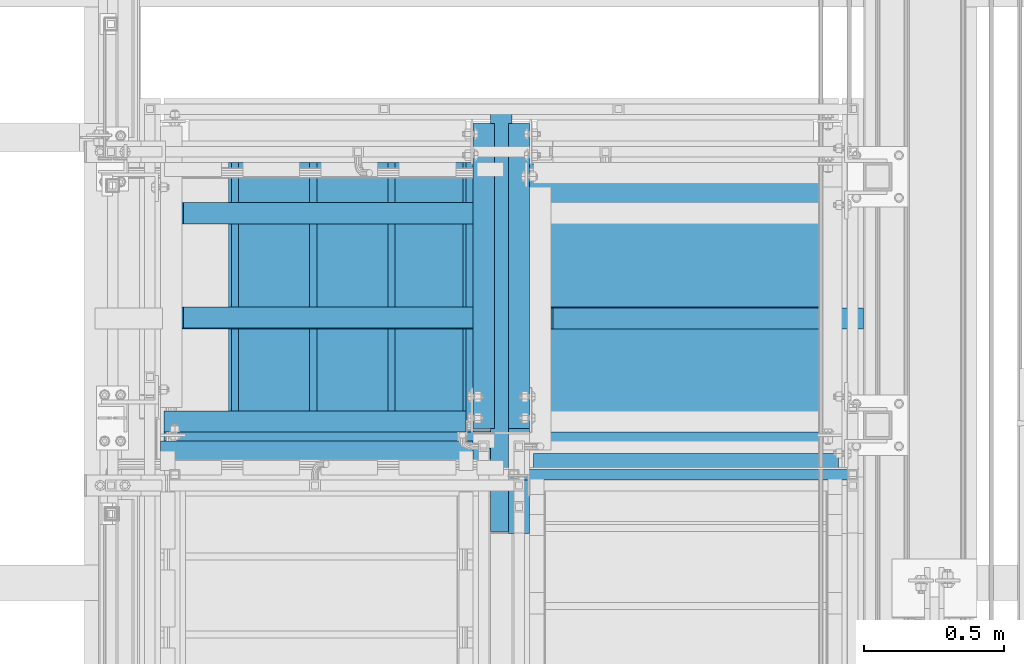
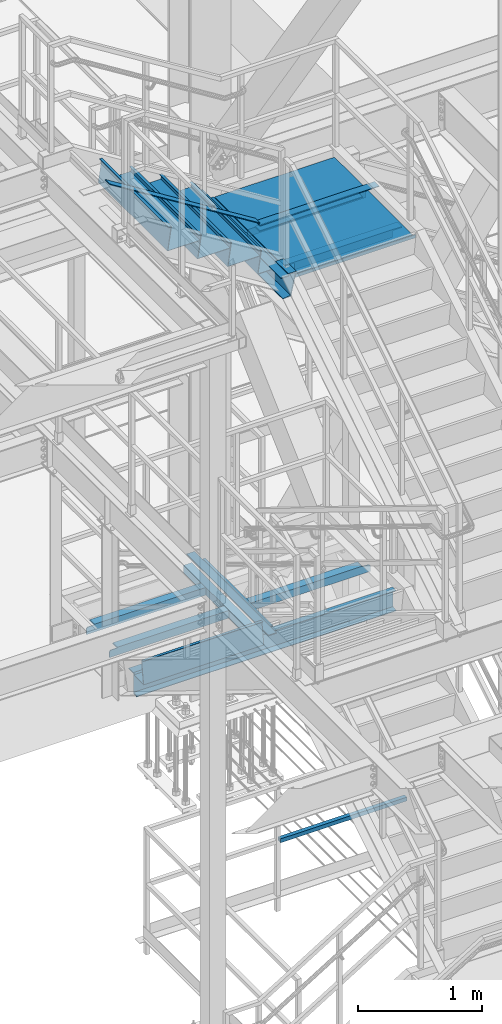
# One storey, part 1774 of 3843: 20 beams, 2 members, 14 elements without a shape of their own.
"""IFC2X3 building model written with IfcOpenShell, lengths in millimetres."""

import ifcopenshell
import ifcopenshell.guid

model = None  # the IFC model being written
_history = None  # IfcOwnerHistory: only IFC2X3 demands one
_inside = {}  # id of a spatial element -> (the spatial element, [elements in it])
_under = {}  # id of a project, library or spatial element -> (it, [spatial elements below it])
_declared = {}  # id of a project -> (the project, [libraries it declares])
_typed = {}  # id of a type object -> (the type object, [elements of that type])
_made_of = {}  # id of a material, layer set ... -> (it, [elements and type objects made of it])


def new_model(schema):
    """Start an empty IFC model of exactly this schema.

    Asked for "IFC4X3", IfcOpenShell would pick the latest addendum, in which some entities
    have other attributes; the version numbers below select the first issue.
    IFC2X3 requires an IfcOwnerHistory on every rooted entity: one is made here for all.
    """
    global model, _history
    if schema == "IFC4X3":
        model = ifcopenshell.file(schema_version=(4, 3, 0, 0))
    else:
        model = ifcopenshell.file(schema=schema)
    _inside.clear()
    _under.clear()
    _declared.clear()
    _typed.clear()
    _made_of.clear()
    _history = None
    if model.schema == "IFC2X3":
        org = make("IfcOrganization", Name="unknown")
        user = make(
            "IfcPersonAndOrganization",
            ThePerson=make("IfcPerson", FamilyName="unknown"),
            TheOrganization=org,
        )
        app = make(
            "IfcApplication",
            ApplicationDeveloper=org,
            Version="unknown",
            ApplicationFullName="unknown",
            ApplicationIdentifier="unknown",
        )
        _history = make(
            "IfcOwnerHistory",
            OwningUser=user,
            OwningApplication=app,
            ChangeAction="ADDED",
            CreationDate=0,
        )
    return model


def make(cls, **values):
    """One entity of the class cls with the attributes given. An attribute that is None is left unset."""
    return model.create_entity(
        cls, **{name: value for name, value in values.items() if value is not None}
    )


def rooted(cls, **values):
    """An entity with a GlobalId (a new one), such as an element, a storey or a relation."""
    return make(cls, GlobalId=ifcopenshell.guid.new(), OwnerHistory=_history, **values)


def si_unit(unit_type, name, prefix=None):
    """IfcSIUnit, for example si_unit("LENGTHUNIT", "METRE", prefix="MILLI")."""
    return make("IfcSIUnit", UnitType=unit_type, Prefix=prefix, Name=name)


def assignment(units):
    """IfcUnitAssignment: the units of a project."""
    return None if units is None else make("IfcUnitAssignment", Units=units)


def point(xyz):
    """IfcCartesianPoint."""
    return None if xyz is None else make("IfcCartesianPoint", Coordinates=xyz)


def direction(xyz):
    """IfcDirection."""
    return None if xyz is None else make("IfcDirection", DirectionRatios=xyz)


def frame(location, z_axis=None, x_axis=None):
    """IfcAxis2Placement3D, a coordinate frame: its origin and axes. An axis left out is left unset."""
    return make(
        "IfcAxis2Placement3D",
        Location=point(location),
        Axis=direction(z_axis),
        RefDirection=direction(x_axis),
    )


def origin_with_axes():
    """The frame at (0, 0, 0) with the z axis (0, 0, 1) and the x axis (1, 0, 0) written out."""
    return frame((0.0, 0.0, 0.0), z_axis=(0.0, 0.0, 1.0), x_axis=(1.0, 0.0, 0.0))


def place(relative_to, where):
    """IfcLocalPlacement: puts the frame where relative to a parent placement (None: the world)."""
    return make(
        "IfcLocalPlacement", PlacementRelTo=relative_to, RelativePlacement=where
    )


def context(
    kind, dimensions, precision=None, world=None, true_north=None, identifier=None
):
    """IfcGeometricRepresentationContext, for example the 3D "Model" context."""
    return make(
        "IfcGeometricRepresentationContext",
        ContextIdentifier=identifier,
        ContextType=kind,
        CoordinateSpaceDimension=dimensions,
        Precision=precision,
        WorldCoordinateSystem=world,
        TrueNorth=true_north,
    )


def subcontext(parent, identifier, kind, view, scale=None):
    """IfcGeometricRepresentationSubContext, for example "Body" below "Model"."""
    return make(
        "IfcGeometricRepresentationSubContext",
        ContextIdentifier=identifier,
        ContextType=kind,
        ParentContext=parent,
        TargetScale=scale,
        TargetView=view,
    )


def project(units=None, contexts=None):
    """IfcProject with its units and contexts."""
    return rooted(
        "IfcProject",
        Name="project",
        RepresentationContexts=contexts,
        UnitsInContext=assignment(units),
    )


def spatial(cls, under=None, at=None, **own):
    """A site, building, storey or space (cls), placed at a placement, below another one or the project."""
    s = rooted(cls, ObjectPlacement=at, **own)
    if under is not None:
        _under.setdefault(under.id(), (under, []))[1].append(s)
    return s


def faces_of(points, faces, orient=None, outer=None):
    """IfcFace entities. A face is a list of loops; a loop is a list of indices into points, from 0.

    orient and outer hold one flag for each loop. By default every Orientation is true, the
    first loop of a face is its IfcFaceOuterBound and the others are IfcFaceBound.
    """
    made = []
    for i, loops in enumerate(faces):
        bounds = []
        for j, loop in enumerate(loops):
            is_outer = j == 0 if outer is None else outer[i][j]
            bounds.append(
                make(
                    "IfcFaceOuterBound" if is_outer else "IfcFaceBound",
                    Bound=make("IfcPolyLoop", Polygon=[points[k] for k in loop]),
                    Orientation=True if orient is None else orient[i][j],
                )
            )
        made.append(make("IfcFace", Bounds=bounds))
    return made


def faceted_brep(points, faces, orient=None, outer=None, voids=None):
    """IfcFacetedBrep: a solid bounded by flat faces; with voids (closed shells), ...WithVoids."""
    shared = [point(p) for p in points]
    hull = make("IfcClosedShell", CfsFaces=faces_of(shared, faces, orient, outer))
    if voids is None:
        return make("IfcFacetedBrep", Outer=hull)
    return make(
        "IfcFacetedBrepWithVoids",
        Outer=hull,
        Voids=[
            make(cls, CfsFaces=faces_of(shared, fs, o, b)) for cls, fs, o, b in voids
        ],
    )


def shape(context_of_items, identifier, shape_type, items):
    """IfcShapeRepresentation: the items that make up one representation, for example the "Body"."""
    return make(
        "IfcShapeRepresentation",
        ContextOfItems=context_of_items,
        RepresentationIdentifier=identifier,
        RepresentationType=shape_type,
        Items=items,
    )


def material(Name=None, Category=None):
    """IfcMaterial."""
    return make("IfcMaterial", Name=Name, Category=Category)


def made_of(thing, what):
    """Note that an element or type object is made of a material, layer set ...; save() writes the relation."""
    if what is not None:
        _made_of.setdefault(what.id(), (what, []))[1].append(thing)
    return thing


def type_object(cls, material=None, **own):
    """A type object (cls), such as IfcWallType, which elements share."""
    return made_of(rooted(cls, **own), material)


def element(
    cls,
    number,
    at=None,
    inside=None,
    cuts=None,
    type_object=None,
    material=None,
    context=None,
    identifier="Body",
    shape_type=None,
    held_by="IfcProductDefinitionShape",
    body=None,
    shapes=None,
    **own,
):
    """One element of the class cls, such as IfcWall. Its Tag is "e" and its number.

    at: its placement. inside: the storey or other place that contains it. cuts: it is an
    opening in that element (IfcRelVoidsElement). A single representation is given by context,
    identifier, shape_type and body (its items); several are given by shapes. held_by: the class
    of the entity that holds the representations. save() writes the other relations.
    """
    e = rooted(cls, Tag="e%d" % number, ObjectPlacement=at, **own)
    if body is not None:
        shapes = [shape(context, identifier, shape_type, body)]
    if shapes is not None:
        e.Representation = make(held_by, Representations=shapes)
    if inside is not None:
        _inside.setdefault(inside.id(), (inside, []))[1].append(e)
    if cuts is not None:
        rooted(
            "IfcRelVoidsElement", RelatingBuildingElement=cuts, RelatedOpeningElement=e
        )
    if type_object is not None:
        _typed.setdefault(type_object.id(), (type_object, []))[1].append(e)
    return made_of(e, material)


def aggregate(whole, parts):
    """IfcRelAggregates: a whole, such as a stair, and the parts it consists of."""
    return rooted("IfcRelAggregates", RelatingObject=whole, RelatedObjects=parts)


def save(model, path):
    """Write the relations noted so far, then the file.

    IfcRelAggregates (storeys below a building ...), IfcRelContainedInSpatialStructure (elements
    in a storey), IfcRelDefinesByType, IfcRelAssociatesMaterial and IfcRelDeclares: one each for
    every whole, place, type object, material and project.
    """
    for whole, parts in _under.values():
        aggregate(whole, parts)
    for where, things in _inside.values():
        rooted(
            "IfcRelContainedInSpatialStructure",
            RelatedElements=things,
            RelatingStructure=where,
        )
    for kind, things in _typed.values():
        rooted("IfcRelDefinesByType", RelatedObjects=things, RelatingType=kind)
    for what, things in _made_of.values():
        rooted("IfcRelAssociatesMaterial", RelatedObjects=things, RelatingMaterial=what)
    for by, libraries in _declared.values():
        rooted("IfcRelDeclares", RelatingContext=by, RelatedDefinitions=libraries)
    model.write(path)


model = new_model("IFC2X3")

# Units and contexts
model_context = context("Model", 3, precision=1e-05, world=origin_with_axes())
body_context = subcontext(model_context, "Body", "Model", "MODEL_VIEW")
ifc_project = project(units=[si_unit("LENGTHUNIT", "METRE", prefix="MILLI"), si_unit("AREAUNIT", "SQUARE_METRE"), si_unit("VOLUMEUNIT", "CUBIC_METRE"), si_unit("MASSUNIT", "GRAM", prefix="KILO"), si_unit("TIMEUNIT", "SECOND"), si_unit("PLANEANGLEUNIT", "RADIAN"), si_unit("SOLIDANGLEUNIT", "STERADIAN"), si_unit("THERMODYNAMICTEMPERATUREUNIT", "DEGREE_CELSIUS"), si_unit("LUMINOUSINTENSITYUNIT", "LUMEN")], contexts=[model_context])

# Site, building, storey
site_placement = place(None, origin_with_axes())
site = spatial("IfcSite", under=ifc_project, at=site_placement, CompositionType="ELEMENT")
building_placement = place(site_placement, origin_with_axes())
building = spatial("IfcBuilding", under=site, at=building_placement, Name="Undefined", CompositionType="ELEMENT")
storey_placement = place(building_placement, origin_with_axes())
storey = spatial("IfcBuildingStorey", under=building, at=storey_placement, Name="Undefined", CompositionType="ELEMENT", Elevation=0.0)

# Assembly, beam
assembly_1_placement = place(storey_placement, origin_with_axes())
assembly_1 = element("IfcElementAssembly", 1, at=assembly_1_placement, inside=storey, Name="RAIL", AssemblyPlace="NOTDEFINED", PredefinedType="RIGID_FRAME")
ifc_material_1 = material()
beam_type_1 = type_object("IfcBeamType", Name="HSS1-1/2X1-1/2X1/4", PredefinedType="NOTDEFINED")
beam_1_placement = place(assembly_1_placement, frame((54425.8499995321, 21755.0999999874, 31013.4), z_axis=(0.0, 0.0, 1.0), x_axis=(1.0, 0.0, 0.0)))
beam_1 = element("IfcBeam", 2, at=beam_1_placement, type_object=beam_type_1, material=ifc_material_1, Name="RAIL", ObjectType="HSS1-1/2X1-1/2X1/4", context=body_context, shape_type="Brep", body=[
    faceted_brep([(1193.8000007628, -19.0499992350015, 19.0499992350015), (1193.80000076281, -19.0499992350015, -19.0499992350015), (1193.80000076281, 19.0499992350015, -19.0499992350015), (1193.8000007628, 19.0499992350015, 19.0499992350015), (1193.8000007628, -12.6999993299978, 12.6999993299978), (1193.8000007628, 12.6999993299978, 12.6999993299978), (1193.8000007628, 12.6999993299978, -12.6999993299978), (1193.8000007628, -12.6999993299978, -12.6999993299978), (19.0499992350015, 19.0499992350015, -19.0499992350015), (19.0499992350015, 19.0499992350015, 19.0499992350015), (19.0499992350015, -19.0499992350015, 19.0499992350015), (19.0499992350015, -19.0499992350015, -19.0499992350015), (19.0499992350015, 12.6999993299978, 12.6999993299978), (19.0499992350015, -12.6999993299978, 12.6999993299978), (19.0499992350015, -12.6999993299978, -12.6999993299978), (19.0499992350015, 12.6999993299978, -12.6999993299978)], [[[0, 1, 2, 3], [4, 5, 6, 7]], [[8, 9, 3, 2]], [[9, 10, 0, 3]], [[10, 11, 1, 0]], [[11, 8, 2, 1]], [[11, 10, 9, 8], [12, 13, 14, 15]], [[14, 13, 4, 7]], [[15, 14, 7, 6]], [[12, 15, 6, 5]], [[13, 12, 5, 4]]]),
])
aggregate(assembly_1, [beam_1])

assembly_2_placement = place(storey_placement, origin_with_axes())
assembly_2 = element("IfcElementAssembly", 3, at=assembly_2_placement, inside=storey, Name="ref.", AssemblyPlace="NOTDEFINED", PredefinedType="RIGID_FRAME")
ifc_material_2 = material(Name="STEEL/Steel_Undefined")
beam_type_2 = type_object("IfcBeamType", PredefinedType="NOTDEFINED")
beam_2_placement = place(assembly_2_placement, frame((54566.477134449, 22313.9000000151, 36691.3583313009), z_axis=(0.0, 1.0, 0.0), x_axis=(1.0, 0.0, 0.0)))
beam_2 = element("IfcBeam", 4, at=beam_2_placement, type_object=beam_type_2, material=ifc_material_2, Name="ref.", context=body_context, shape_type="Brep", body=[
    faceted_brep([(0.0, 3.17500000000291, -38.0999999999985), (0.0, 3.17500000000291, 38.0999999999985), (1110.32286554994, 3.17500000000291, 38.0999999999985), (1110.32286554994, 3.17500000000291, -38.0999999999985), (0.0, -3.17500000000291, 38.0999999999985), (1110.32286554994, -3.17500000000291, 38.0999999999985), (0.0, -3.17500000000291, -38.0999999999985), (1110.32286554994, -3.17500000000291, -38.0999999999985)], [[[0, 1, 2, 3]], [[1, 4, 5, 2]], [[4, 6, 7, 5]], [[6, 0, 3, 7]], [[5, 7, 3, 2]], [[6, 4, 1, 0]]]),
])
aggregate(assembly_2, [beam_2])

assembly_3_placement = place(storey_placement, origin_with_axes())
assembly_3 = element("IfcElementAssembly", 5, at=assembly_3_placement, inside=storey, Name="ref.", AssemblyPlace="NOTDEFINED", PredefinedType="RIGID_FRAME")
beam_3_placement = place(assembly_3_placement, frame((54381.4, 21551.9000000047, 36691.358331298), z_axis=(-1.0, 0.0, 0.0), x_axis=(0.0, 1.0, 0.0)))
beam_3 = element("IfcBeam", 6, at=beam_3_placement, type_object=beam_type_2, material=ifc_material_2, Name="ref.", context=body_context, shape_type="Brep", body=[
    faceted_brep([(0.0, 3.17500000000291, -38.0999999999985), (0.0, 3.17500000000291, 38.0999999999985), (1397.00000007718, 3.17500000000291, 38.0999999999985), (1397.00000007718, 3.17500000000291, -38.0999999999985), (0.0, -3.17500000000291, 38.0999999999985), (1397.00000007718, -3.17500000000291, 38.0999999999985), (0.0, -3.17500000000291, -38.0999999999985), (1397.00000007718, -3.17500000000291, -38.0999999999985)], [[[0, 1, 2, 3]], [[1, 4, 5, 2]], [[4, 6, 7, 5]], [[6, 0, 3, 7]], [[5, 7, 3, 2]], [[6, 4, 1, 0]]]),
])
aggregate(assembly_3, [beam_3])

# Assembly, beams
assembly_4_placement = place(storey_placement, origin_with_axes())
assembly_4 = element("IfcElementAssembly", 7, at=assembly_4_placement, inside=storey, Name="STAIR", AssemblyPlace="NOTDEFINED", PredefinedType="RIGID_FRAME")
ifc_material_3 = material(Name="STEEL/A36")
beam_4_placement = place(assembly_4_placement, frame((54444.9, 21748.7500000874, 36640.5583313878), z_axis=(-1.0, 0.0, 0.0), x_axis=(0.0, 1.0, 0.0)))
beam_4 = element("IfcBeam", 8, at=beam_4_placement, type_object=beam_type_2, material=ifc_material_3, Name="PLATE", context=body_context, shape_type="Brep", body=[
    faceted_brep([(0.0, 3.17500000000291, -38.0999999999985), (0.0, 3.17500000000291, 38.0999999999985), (1111.25000001924, 3.17500000000291, 38.0999999999985), (1111.25000001924, 3.17500000000291, -38.0999999999985), (0.0, -3.17500000000291, 38.0999999999985), (1111.25000001924, -3.17500000000291, 38.0999999999985), (0.0, -3.17500000000291, -38.0999999999985), (1111.25000001924, -3.17500000000291, -38.0999999999985)], [[[0, 1, 2, 3]], [[1, 4, 5, 2]], [[4, 6, 7, 5]], [[6, 0, 3, 7]], [[5, 7, 3, 2]], [[6, 4, 1, 0]]]),
])
beam_type_3 = type_object("IfcBeamType", Name="C12X20.7", PredefinedType="NOTDEFINED")
beam_5_placement = place(assembly_4_placement, frame((54444.9000000002, 22948.9000000157, 36567.5333313329), z_axis=(0.0, 0.0, 1.0), x_axis=(0.0, -1.0, 0.0)))
beam_5 = element("IfcBeam", 9, at=beam_5_placement, type_object=beam_type_3, material=ifc_material_3, Name="STAIR", ObjectType="C12X20.7", context=body_context, shape_type="Brep", body=[
    faceted_brep([(1200.14999992837, 30.1624999999985, 69.8500000521308), (1200.14999992837, 38.0999999999985, 69.8500000521308), (88.8999999338557, 38.0999999999985, 69.8500000497079), (88.8999999338557, 30.1624999999985, 69.8500000497079), (1200.14999992838, -38.0999999999985, 152.400000013644), (1200.14999992838, 38.0999999999985, 152.400000000001), (1200.14999992838, 30.1624999999985, 134.674927499997), (1200.14999992838, -38.0999999999985, 146.047460000002), (88.8999999464759, 30.1625000000058, -134.6749275), (88.8999999464759, -38.1000000000058, -146.047460000002), (1318.77153195494, -38.0999999999985, -146.047460000002), (1322.02977795773, 30.1624999999985, -134.674927499997), (88.8999999464759, -38.1000000000058, -152.400000000001), (1316.95152061951, -38.0999999999985, -152.400000000001), (88.8999999464759, 38.1000000000058, -152.400000000001), (1316.95152061951, 38.0999999999985, -152.400000000001), (1404.27713447458, -38.0999999999985, 152.400000000001), (1402.45712313915, -38.0999999999985, 146.047460000002), (1399.19887713636, 30.1624999999985, 134.674927499997), (1404.27713447458, 38.0999999999985, 152.400000000001), (88.8999999338557, 30.1624999999985, 50.8000000163374), (88.8999999338557, 30.1624999999985, -103.599999983664)], [[[0, 1, 2, 3]], [[4, 5, 1, 0, 6, 7]], [[8, 9, 10, 11]], [[9, 12, 13, 10]], [[12, 14, 15, 13]], [[16, 17, 18, 11, 10, 13, 15, 19]], [[17, 16, 4, 7]], [[18, 17, 7, 6]], [[3, 20, 21, 8, 11, 18, 6, 0]], [[14, 12, 9, 8, 21, 20, 3, 2]], [[19, 15, 14, 2, 1, 5]], [[16, 19, 5, 4]]]),
])
beam_type_4 = type_object("IfcBeamType", Name="L3X3X1/4", PredefinedType="NOTDEFINED")
beam_6_placement = place(assembly_4_placement, frame((54483.0000000024, 22313.9, 36605.6333313878), z_axis=(0.0, -1.0, 0.0), x_axis=(1.0, 0.0, 0.0)))
beam_6 = element("IfcBeam", 10, at=beam_6_placement, type_object=beam_type_4, material=ifc_material_3, Name="ANGLE", ObjectType="L3X3X1/4", context=body_context, shape_type="Brep", body=[
    faceted_brep([(1041.40000012286, 31.75, 38.0999999999985), (1041.40000012286, 31.75, -31.75), (1041.40000012286, 31.7499999942156, -38.0999999999985), (1035.05000012226, 38.0999999999985, -38.0999999999985), (1035.05000012226, 38.0999999999985, 38.0999999999985), (1098.55000012286, 31.75, -31.75), (1098.55000012286, 31.7499999942156, -38.0999999999985), (1111.25000012285, 19.0499999942185, -31.75), (1111.25000012285, 19.0499999942185, -38.0999999999985), (1111.25000012344, -38.1000000057757, -31.75), (1111.25000012344, -38.0999999999985, -38.0999999999985), (82.5500000005923, 38.0999999999985, 38.0999999999985), (82.5499948264696, 38.0999999999458, -38.0999999999985), (76.1999999999971, 31.7499999999927, -38.0999999999985), (76.1999999999971, 31.75, -31.75), (76.1999999999971, 31.75, 38.0999999999985), (19.0499999999956, 31.7499999999927, -38.0999999999985), (19.0500000000029, 31.75, -31.75), (6.34999999999854, 19.0499999999956, -38.0999999999985), (6.34999999999854, 19.0499999999956, -31.75), (6.34999999941647, -38.0999999999985, -31.75), (6.34999999941647, -38.0999999999985, -38.0999999999985)], [[[0, 1, 2, 3, 4]], [[5, 6, 2, 1]], [[7, 8, 6, 5]], [[9, 10, 8, 7]], [[11, 12, 13, 14, 15]], [[14, 13, 16, 17]], [[17, 16, 18, 19]], [[20, 19, 18, 21]], [[5, 1, 14, 17, 19, 20, 9, 7]], [[15, 14, 1, 0]], [[11, 15, 0, 4]], [[12, 11, 4, 3]], [[21, 18, 16, 13, 12, 3, 2, 6, 8, 10]], [[20, 21, 10, 9]]]),
])
beam_7_placement = place(assembly_4_placement, frame((55587.8999999184, 21793.2, 36605.6333313961), z_axis=(0.0, 1.0, 0.0), x_axis=(-1.0, 0.0, 0.0)))
beam_7 = element("IfcBeam", 11, at=beam_7_placement, type_object=beam_type_4, material=ifc_material_3, Name="ANGLE", ObjectType="L3X3X1/4", context=body_context, shape_type="Brep", body=[
    faceted_brep([(0.0, 25.3999999519947, -31.75), (0.0, 25.4000000000015, -38.0999999999985), (88.9000015258935, 25.399999952002, -38.0999999999985), (88.9000015258935, 25.399999952002, -31.75), (88.9000015261336, -38.1000000000131, -31.75), (88.9000015261336, -38.0999999999985, -38.0999999999985), (0.0, 38.0999999999985, -38.0999999999985), (0.0, 38.0999999999985, 38.0999999999985), (1092.20000022635, 38.0999999990308, 38.0999999999985), (1092.20000022635, 38.0999999990308, -38.0999999999985), (0.0, 31.75, 38.0999999999985), (1092.19999991878, 31.75, 38.0999999999985), (0.0, 31.75, -31.75), (1092.20000022113, 31.75, -31.75), (1092.19999991823, 25.3999999520238, -31.75), (1092.19999991849, 25.3999999520238, -38.0999999999985), (1003.29999839235, 25.3999999520238, -31.75), (1003.29999839235, 25.3999999520238, -38.0999999999985), (1003.29999998639, -38.0999999999985, -31.75), (1003.29999998639, -38.0999999999985, -38.0999999999985)], [[[0, 1, 2, 3]], [[4, 3, 2, 5]], [[6, 7, 8, 9]], [[7, 10, 11, 8]], [[10, 12, 13, 11]], [[9, 8, 11, 13, 14, 15]], [[14, 16, 17, 15]], [[18, 19, 17, 16]], [[19, 18, 4, 5]], [[1, 6, 9, 15, 17, 19, 5, 2]], [[12, 10, 7, 6, 1, 0]], [[18, 16, 14, 13, 12, 0, 3, 4]]]),
])

# Assembly, beam
assembly_5_placement = place(storey_placement, origin_with_axes())
assembly_5 = element("IfcElementAssembly", 12, at=assembly_5_placement, inside=storey, Name="ANGLE", AssemblyPlace="NOTDEFINED", PredefinedType="RIGID_FRAME")
beam_8_placement = place(assembly_5_placement, frame((55600.6000026965, 22318.1333333357, 32970.1768416983), z_axis=(0.0, 1.0, 0.0), x_axis=(-1.0, 0.0, 0.0)))
beam_8 = element("IfcBeam", 13, at=beam_8_placement, type_object=beam_type_4, material=ifc_material_3, Name="ANGLE", ObjectType="L3X3X1/4", context=body_context, shape_type="Brep", body=[
    faceted_brep([(6.34999999941647, -38.0999999999985, -31.75), (6.34999999999854, 19.0499999999956, -31.75), (6.34999999999854, 19.0499999999956, -38.0999999999985), (6.34999999941647, -38.0999999999985, -38.0999999999985), (19.0500000000029, 31.75, -31.75), (19.0499999999956, 31.7499999999927, -38.0999999999985), (76.1999999999971, 31.75, -31.75), (76.1999999999971, 31.7499999999927, -38.0999999999985), (82.5500000005923, 38.0999999999985, 38.0999999999985), (82.5499948264696, 38.0999999999458, -38.0999999999985), (76.1999999999971, 31.75, 38.0999999999985), (1117.60000005434, 31.7499999977736, 38.0999999999985), (1117.60000005434, 31.7499999977736, -31.75), (1117.6000000542, -38.100000002225, -31.75), (1117.6000000542, -38.100000002225, -38.0999999999985), (1117.60000005436, 38.0999999977794, -38.0999999999985), (1117.60000005436, 38.0999999977794, 38.0999999999985)], [[[0, 1, 2, 3]], [[4, 5, 2, 1]], [[6, 7, 5, 4]], [[8, 9, 7, 6, 10]], [[11, 12, 13, 14, 15, 16]], [[11, 16, 8, 10]], [[12, 11, 10, 6]], [[1, 0, 13, 12, 6, 4]], [[14, 13, 0, 3]], [[15, 14, 3, 2, 5, 7, 9]], [[16, 15, 9, 8]]]),
])
aggregate(assembly_5, [beam_8])

assembly_6_placement = place(storey_placement, origin_with_axes())
assembly_6 = element("IfcElementAssembly", 14, at=assembly_6_placement, inside=storey, Name="ANGLE", AssemblyPlace="NOTDEFINED", PredefinedType="RIGID_FRAME")
beam_9_placement = place(assembly_6_placement, frame((54279.8000026911, 22318.1333333357, 32970.1768416983), z_axis=(0.0, 1.0, 0.0), x_axis=(-1.0, 0.0, 0.0)))
beam_9 = element("IfcBeam", 15, at=beam_9_placement, type_object=beam_type_4, material=ifc_material_3, Name="ANGLE", ObjectType="L3X3X1/4", context=body_context, shape_type="Brep", body=[
    faceted_brep([(1041.40000012286, 31.75, 38.0999999999985), (1041.40000012286, 31.75, -31.75), (1041.40000012286, 31.7499999942156, -38.0999999999985), (1035.05000012226, 38.0999999999985, -38.0999999999985), (1035.05000012226, 38.0999999999985, 38.0999999999985), (1098.55000012286, 31.75, -31.75), (1098.55000012286, 31.7499999942156, -38.0999999999985), (1111.25000012285, 19.0499999942185, -31.75), (1111.25000012285, 19.0499999942185, -38.0999999999985), (1111.25000012344, -38.1000000057757, -31.75), (1111.25000012344, -38.0999999999985, -38.0999999999985), (0.0, -38.0999999999985, -38.0999999999985), (0.0, -38.0999999999985, -31.75), (0.0, 31.75, -31.75), (0.0, 31.75, 38.0999999999985), (0.0, 38.0999999999985, 38.0999999999985), (0.0, 38.0999999999985, -38.0999999999985)], [[[0, 1, 2, 3, 4]], [[5, 6, 2, 1]], [[7, 8, 6, 5]], [[9, 10, 8, 7]], [[11, 12, 13, 14, 15, 16]], [[5, 1, 13, 12, 9, 7]], [[14, 13, 1, 0]], [[15, 14, 0, 4]], [[16, 15, 4, 3]], [[11, 16, 3, 2, 6, 8, 10]], [[12, 11, 10, 9]]]),
])
aggregate(assembly_6, [beam_9])

assembly_7_placement = place(storey_placement, origin_with_axes())
assembly_7 = element("IfcElementAssembly", 16, at=assembly_7_placement, inside=storey, Name="ANGLE", AssemblyPlace="NOTDEFINED", PredefinedType="RIGID_FRAME")
beam_10_placement = place(assembly_7_placement, frame((54279.8000026911, 22690.6666666681, 32970.1768416983), z_axis=(0.0, 1.0, 0.0), x_axis=(-1.0, 0.0, 0.0)))
beam_10 = element("IfcBeam", 17, at=beam_10_placement, type_object=beam_type_4, material=ifc_material_3, Name="ANGLE", ObjectType="L3X3X1/4", context=body_context, shape_type="Brep", body=[
    faceted_brep([(1041.40000012286, 31.75, 38.0999999999985), (1041.40000012286, 31.75, -31.75), (1041.40000012286, 31.7499999942156, -38.0999999999985), (1035.05000012226, 38.0999999999985, -38.0999999999985), (1035.05000012226, 38.0999999999985, 38.0999999999985), (1098.55000012286, 31.75, -31.75), (1098.55000012286, 31.7499999942156, -38.0999999999985), (1111.25000012285, 19.0499999942185, -31.75), (1111.25000012285, 19.0499999942185, -38.0999999999985), (1111.25000012344, -38.1000000057757, -31.75), (1111.25000012344, -38.0999999999985, -38.0999999999985), (0.0, -38.0999999999985, -38.0999999999985), (0.0, -38.0999999999985, -31.75), (0.0, 31.75, -31.75), (0.0, 31.75, 38.0999999999985), (0.0, 38.0999999999985, 38.0999999999985), (0.0, 38.0999999999985, -38.0999999999985)], [[[0, 1, 2, 3, 4]], [[5, 6, 2, 1]], [[7, 8, 6, 5]], [[9, 10, 8, 7]], [[11, 12, 13, 14, 15, 16]], [[5, 1, 13, 12, 9, 7]], [[14, 13, 1, 0]], [[15, 14, 0, 4]], [[16, 15, 4, 3]], [[11, 16, 3, 2, 6, 8, 10]], [[12, 11, 10, 9]]]),
])
aggregate(assembly_7, [beam_10])

assembly_8_placement = place(storey_placement, origin_with_axes())
assembly_8 = element("IfcElementAssembly", 18, at=assembly_8_placement, inside=storey, Name="ANGLE", AssemblyPlace="NOTDEFINED", PredefinedType="RIGID_FRAME")
beam_11_placement = place(assembly_8_placement, frame((54444.8999999809, 23012.4000001911, 32970.1768417302), z_axis=(-1.0, 0.0, 0.0), x_axis=(0.0, -1.0, 0.0)))
beam_11 = element("IfcBeam", 19, at=beam_11_placement, type_object=beam_type_4, material=ifc_material_3, Name="ANGLE", ObjectType="L3X3X1/4", context=body_context, shape_type="Brep", body=[
    faceted_brep([(0.0, 38.0999999999985, -38.0999999999985), (0.0, 38.0999999999985, 38.0999999999985), (1092.20000022635, 38.0999999990308, 38.0999999999985), (1092.20000022635, 38.0999999990308, -38.0999999999985), (0.0, 31.75, 38.0999999999985), (1092.19999991878, 31.75, 38.0999999999985), (0.0, 31.75, -31.75), (1092.20000022113, 31.75, -31.75), (0.0, -38.0999999999985, -31.75), (1092.20000037892, -38.0999999999985, -31.75), (0.0, -38.0999999999985, -38.0999999999985), (1092.20000037892, -38.0999999999985, -38.0999999999985)], [[[0, 1, 2, 3]], [[1, 4, 5, 2]], [[4, 6, 7, 5]], [[6, 8, 9, 7]], [[8, 10, 11, 9]], [[10, 0, 3, 11]], [[5, 7, 9, 11, 3, 2]], [[10, 8, 6, 4, 1, 0]]]),
])
aggregate(assembly_8, [beam_11])

assembly_9_placement = place(storey_placement, origin_with_axes())
assembly_9 = element("IfcElementAssembly", 20, at=assembly_9_placement, inside=storey, Name="ANGLE", AssemblyPlace="NOTDEFINED", PredefinedType="RIGID_FRAME")
beam_12_placement = place(assembly_9_placement, frame((54317.9000000233, 21920.1999998122, 32970.1768416983), z_axis=(1.0, 0.0, 0.0), x_axis=(0.0, 1.0, 0.0)))
beam_12 = element("IfcBeam", 21, at=beam_12_placement, type_object=beam_type_4, material=ifc_material_3, Name="ANGLE", ObjectType="L3X3X1/4", context=body_context, shape_type="Brep", body=[
    faceted_brep([(0.0, 38.0999999999985, -38.0999999999985), (0.0, 38.0999999999985, 38.0999999999985), (1092.20000022635, 38.0999999990308, 38.0999999999985), (1092.20000022635, 38.0999999990308, -38.0999999999985), (0.0, 31.75, 38.0999999999985), (1092.19999991878, 31.75, 38.0999999999985), (0.0, 31.75, -31.75), (1092.20000022113, 31.75, -31.75), (0.0, -38.0999999999985, -31.75), (1092.20000037892, -38.0999999999985, -31.75), (0.0, -38.0999999999985, -38.0999999999985), (1092.20000037892, -38.0999999999985, -38.0999999999985)], [[[0, 1, 2, 3]], [[1, 4, 5, 2]], [[4, 6, 7, 5]], [[6, 8, 9, 7]], [[8, 10, 11, 9]], [[10, 0, 3, 11]], [[5, 7, 9, 11, 3, 2]], [[10, 8, 6, 4, 1, 0]]]),
])
aggregate(assembly_9, [beam_12])

assembly_10_placement = place(storey_placement, origin_with_axes())
assembly_10 = element("IfcElementAssembly", 22, at=assembly_10_placement, inside=storey, Name="BEAM", AssemblyPlace="NOTDEFINED", PredefinedType="RIGID_FRAME")
beam_13_placement = place(assembly_10_placement, frame((54254.4000083182, 21945.5999999342, 32970.1770777909), z_axis=(0.0, 1.0, 0.0), x_axis=(-1.0, 0.0, 0.0)))
beam_13 = element("IfcBeam", 23, at=beam_13_placement, type_object=beam_type_4, material=ifc_material_3, Name="ANGLE", ObjectType="L3X3X1/4", context=body_context, shape_type="Brep", body=[
    faceted_brep([(1003.29999998639, -38.0999999999985, -31.75), (1003.29999998639, -38.0999999999985, -38.0999999999985), (1003.29999998639, 31.7500000058208, -38.0999999999985), (1003.29999998639, 31.75, -31.75), (1079.50000000556, 31.7499999963184, -31.75), (1079.50000001388, 31.7500016676859, -38.0999999999985), (0.0, 31.75, -31.75), (0.0, -38.0999999999985, -31.75), (0.0, -38.0999999999985, -38.0999999999985), (0.0, 38.0999999999985, -38.0999999999985), (1079.50000000558, 38.0999999963169, -38.0999999999985), (0.0, 38.0999999999985, 38.0999999999985), (1079.50000000558, 38.0999999963169, 38.0999999999985), (0.0, 31.75, 38.0999999999985), (1003.29999998639, 31.75, 38.0999999999985), (1079.50000000556, 31.7499999963184, 38.0999999999985)], [[[0, 1, 2, 3]], [[4, 3, 2, 5]], [[6, 7, 0, 3]], [[7, 8, 1, 0]], [[1, 8, 9, 10, 5, 2]], [[9, 11, 12, 10]], [[8, 7, 6, 13, 11, 9]], [[11, 13, 14, 15, 12]], [[10, 12, 15, 4, 5]], [[14, 13, 6, 3, 4, 15]]]),
])

# Assembly, member
assembly_11_placement = place(storey_placement, origin_with_axes())
assembly_11 = element("IfcElementAssembly", 24, at=assembly_11_placement, inside=storey, Name="ref.", AssemblyPlace="NOTDEFINED", PredefinedType="RIGID_FRAME")
member_type = type_object("IfcMemberType", PredefinedType="NOTDEFINED")
member_1_placement = place(assembly_11_placement, frame((54564.7958553098, 22313.9000000151, 36717.2400200574), z_axis=(0.0, -1.0, 0.0), x_axis=(-0.848287005838377, 0.0, 0.529536736899114)))
member_1 = element("IfcMember", 25, at=member_1_placement, type_object=member_type, material=ifc_material_2, Name="ref.", context=body_context, shape_type="Brep", body=[
    faceted_brep([(0.0, 3.17500000000291, -38.0999999999985), (0.0, 3.17500000000291, 38.0999999999985), (1646.84828441072, 3.17500000190194, 38.0999999999985), (1646.84828441072, 3.17500000190194, -38.0999999999985), (0.0, -3.17500000000291, 38.0999999999985), (1646.84828441073, -3.17499999807478, 38.0999999999985), (0.0, -3.17500000000291, -38.0999999999985), (1646.84828441073, -3.17499999807478, -38.0999999999985)], [[[0, 1, 2, 3]], [[1, 4, 5, 2]], [[4, 6, 7, 5]], [[6, 0, 3, 7]], [[5, 7, 3, 2]], [[6, 4, 1, 0]]]),
])
aggregate(assembly_11, [member_1])

assembly_12_placement = place(storey_placement, origin_with_axes())
assembly_12 = element("IfcElementAssembly", 26, at=assembly_12_placement, inside=storey, Name="ref.", AssemblyPlace="NOTDEFINED", PredefinedType="RIGID_FRAME")
member_2_placement = place(assembly_12_placement, frame((54381.4, 21755.1000000032, 33055.9019213117), z_axis=(-1.0, 0.0, 0.0), x_axis=(0.0, 1.0, 0.0)))
member_2 = element("IfcMember", 27, at=member_2_placement, type_object=member_type, material=ifc_material_2, Name="ref.", context=body_context, shape_type="Brep", body=[
    faceted_brep([(0.0, 3.17500000000291, -38.0999999999985), (0.0, 3.17500000000291, 38.0999999999985), (1320.8, 3.17500000000291, 38.0999999999985), (1320.8, 3.17500000000291, -38.0999999999985), (0.0, -3.17500000000291, 38.0999999999985), (1320.8, -3.17500000000291, 38.0999999999985), (0.0, -3.17500000000291, -38.0999999999985), (1320.8, -3.17500000000291, -38.0999999999985)], [[[0, 1, 2, 3]], [[1, 4, 5, 2]], [[4, 6, 7, 5]], [[6, 0, 3, 7]], [[5, 7, 3, 2]], [[6, 4, 1, 0]]]),
])
aggregate(assembly_12, [member_2])

# Beam
ifc_material_4 = material(Name="STEEL/ASTM A1011")
beam_type_5 = type_object("IfcBeamType", PredefinedType="NOTDEFINED")
beam_14_placement = place(assembly_4_placement, frame((55041.8000001424, 22866.3500000818, 36645.3208312847), z_axis=(1.0, 0.0, 0.0), x_axis=(0.0, -1.0, 0.0)))
beam_14 = element("IfcBeam", 28, at=beam_14_placement, type_object=beam_type_5, material=ifc_material_4, Name="PAN", context=body_context, shape_type="Brep", body=[
    faceted_brep([(0.0, -1.58750000000146, -558.799999999999), (0.0, -1.58750000000146, 558.799999999999), (0.0, 1.58750000000146, 558.799999999999), (0.0, 1.58750000000146, -558.799999999999), (1303.34495559846, 1.58749999418797, 558.800000000003), (1303.34495559846, 1.58749999418797, -558.800000000003), (1300.63495840336, -1.58750000580039, -558.800000000003), (1300.63495840336, -1.58750000580039, 558.800000000003), (1309.26118447979, -35.616162950224, 558.800000000003), (1309.26118447979, -35.616162950224, -558.800000000003), (1306.12558385374, -36.1147947922509, 558.800000000003), (1306.12558385374, -36.1147947922509, -558.800000000003)], [[[0, 1, 2, 3]], [[3, 2, 4, 5]], [[1, 0, 6, 7]], [[5, 4, 8, 9]], [[4, 2, 1, 7, 10, 8]], [[7, 6, 11, 10]], [[6, 0, 3, 5, 9, 11]], [[10, 11, 9, 8]]]),
])

aggregate(assembly_4, [beam_6, beam_7, beam_4, beam_14, beam_5])

beam_type_6 = type_object("IfcBeamType", Name="C8X11.5", PredefinedType="NOTDEFINED")
beam_15_placement = place(assembly_10_placement, frame((55727.5999999994, 21878.9250000032, 32906.6769213187), z_axis=(0.0, 0.0, -1.0), x_axis=(-1.0, 0.0, 0.0)))
beam_15 = element("IfcBeam", 29, at=beam_15_placement, type_object=beam_type_6, material=ifc_material_3, Name="BEAM", ObjectType="C8X11.5", context=body_context, shape_type="Brep", body=[
    faceted_brep([(139.699999998353, -28.5750000000007, -96.8355949999968), (139.699999998353, -28.5750000000007, -101.599999999999), (2552.69999999792, -28.5750000000007, -101.599999999999), (2552.69999999792, -28.5750000000007, -96.8355949999968), (139.699999998353, 22.2249999999985, -88.3723150000005), (2552.69999999792, 22.2249999999985, -88.3723150000005), (139.699999998353, 22.2249999999985, 88.3723150000005), (2552.69999999792, 22.2249999999985, -76.1999999991822), (2552.69999999792, 22.2249999999985, 78.200000000812), (2552.69999999792, 22.2249999999985, 88.3723150000005), (139.699999998353, -28.5750000000007, 96.8355949999968), (2552.69999999792, -28.5750000000007, 96.8355949999968), (139.699999998353, -28.5750000000007, 101.599999999999), (2552.69999999792, -28.5750000000007, 101.599999999999), (139.699999998353, 28.5750000000007, 101.599999999999), (2552.69999999792, 28.5750000000007, 101.599999999999), (139.699999998353, 28.5750000000007, -101.599999999999), (2552.69999999792, 28.5750000000007, -101.599999999999)], [[[0, 1, 2, 3]], [[4, 0, 3, 5]], [[6, 4, 5, 7, 8, 9]], [[10, 6, 9, 11]], [[12, 10, 11, 13]], [[14, 12, 13, 15]], [[1, 0, 4, 6, 10, 12, 14, 16]], [[1, 16, 17, 2]], [[13, 11, 9, 8, 7, 5, 3, 2, 17, 15]], [[16, 14, 15, 17]]]),
])

aggregate(assembly_10, [beam_13, beam_15])

# Assembly, beam
assembly_13_placement = place(storey_placement, origin_with_axes())
assembly_13 = element("IfcElementAssembly", 30, at=assembly_13_placement, inside=storey, Name="STAIR", AssemblyPlace="NOTDEFINED", PredefinedType="RIGID_FRAME")
beam_type_7 = type_object("IfcBeamType", PredefinedType="NOTDEFINED")
beam_16_placement = place(assembly_13_placement, frame((53721.0000001802, 21729.6999999874, 33229.427882758), z_axis=(-1.0, 0.0, 0.0), x_axis=(0.0, 1.0, 0.0)))
beam_16 = element("IfcBeam", 31, at=beam_16_placement, type_object=beam_type_7, material=ifc_material_4, Name="TREAD", context=body_context, shape_type="Brep", body=[
    faceted_brep([(0.0, -1.58750000000146, -558.799999999999), (0.0, -1.58750000000146, 558.799999999999), (0.0, 1.58750000000146, 558.799999999999), (0.0, 1.58750000000146, -558.799999999999), (21.7136676283008, 1.58749999952852, 558.800000000003), (21.7136676283008, 1.58749999952852, -558.800000000003), (25.3999999999942, -1.58750000000146, -558.799999999999), (25.3999999999942, -1.58750000000146, 558.799999999999), (-11.1944922994226, 221.150961432315, 558.800000000003), (-11.1944922994226, 221.150961432315, -558.800000000003), (-7.50815992778007, 217.975961432479, -558.800000000003), (-7.50815992778007, 217.975961432479, 558.800000000003), (146.050000018127, 221.150961439365, 558.800000000003), (146.050000018127, 221.150961439365, -558.800000000003), (146.050000018273, 217.975961439362, 558.800000000003), (146.050000018273, 217.975961439362, -558.800000000003)], [[[0, 1, 2, 3]], [[3, 2, 4, 5]], [[1, 0, 6, 7]], [[5, 4, 8, 9]], [[7, 6, 10, 11]], [[9, 8, 12, 13]], [[8, 4, 2, 1, 7, 11, 14, 12]], [[11, 10, 15, 14]], [[10, 6, 0, 3, 5, 9, 13, 15]], [[14, 15, 13, 12]]]),
])
aggregate(assembly_13, [beam_16])

# Assembly, beams
assembly_14_placement = place(storey_placement, origin_with_axes())
assembly_14 = element("IfcElementAssembly", 32, at=assembly_14_placement, inside=storey, Name="STAIR", AssemblyPlace="NOTDEFINED", PredefinedType="RIGID_FRAME")
beam_type_8 = type_object("IfcBeamType", PredefinedType="NOTDEFINED")
beam_17_placement = place(assembly_14_placement, frame((53416.1999999997, 22313.9000000151, 37390.5991650633), z_axis=(0.0, 1.0, 0.0), x_axis=(1.0, 0.0, 0.0)))
beam_17 = element("IfcBeam", 33, at=beam_17_placement, type_object=beam_type_8, material=ifc_material_4, Name="TREAD", context=body_context, shape_type="Brep", body=[
    faceted_brep([(0.0, -1.58750000000146, -558.799999999999), (0.0, -1.58750000000146, 558.799999999999), (0.0, 1.58750000000146, 558.799999999999), (0.0, 1.58750000000146, -558.799999999999), (21.7291296566655, 1.58749999984138, 558.800000000003), (21.7291296566655, 1.58749999984138, -558.800000000003), (25.3999999999942, -1.58750000000146, -558.799999999999), (25.3999999999942, -1.58750000000146, 558.799999999999), (-11.0689285898225, 226.800833434812, 558.800000000003), (-11.0689285898225, 226.800833434812, -558.800000000003), (-7.39805824649738, 223.625833434788, -558.800000000003), (-7.39805824649738, 223.625833434788, 558.800000000003), (293.731071409333, 226.8008334326, 558.800000000003), (293.731071409333, 226.8008334326, -558.800000000003), (290.984958346977, 223.625833432619, -558.800000000003), (290.984958346977, 223.625833432619, 558.800000000003), (299.617441696697, 186.381090767136, 558.800000000003), (299.617441696697, 186.381090767136, -558.800000000003), (296.47558379783, 185.923538646231, 558.800000000003), (296.47558379783, 185.923538646231, -558.800000000003)], [[[0, 1, 2, 3]], [[3, 2, 4, 5]], [[1, 0, 6, 7]], [[5, 4, 8, 9]], [[7, 6, 10, 11]], [[9, 8, 12, 13]], [[11, 10, 14, 15]], [[13, 12, 16, 17]], [[12, 8, 4, 2, 1, 7, 11, 15, 18, 16]], [[15, 14, 19, 18]], [[14, 10, 6, 0, 3, 5, 9, 13, 17, 19]], [[18, 19, 17, 16]]]),
])
beam_18_placement = place(assembly_14_placement, frame((53695.5999999967, 22313.9000000144, 37216.1858316212), z_axis=(0.0, 1.0, 0.0), x_axis=(1.0, 0.0, 0.0)))
beam_18 = element("IfcBeam", 34, at=beam_18_placement, type_object=beam_type_8, material=ifc_material_4, Name="TREAD", context=body_context, shape_type="Brep", body=[
    faceted_brep([(0.0, -1.58750000000146, -558.799999999999), (0.0, -1.58750000000146, 558.799999999999), (0.0, 1.58750000000146, 558.799999999999), (0.0, 1.58750000000146, -558.799999999999), (21.7291296566655, 1.58749999984138, 558.800000000003), (21.7291296566655, 1.58749999984138, -558.800000000003), (25.3999999999942, -1.58750000000146, -558.799999999999), (25.3999999999942, -1.58750000000146, 558.799999999999), (-11.0689285898225, 226.800833434812, 558.800000000003), (-11.0689285898225, 226.800833434812, -558.800000000003), (-7.39805824649738, 223.625833434788, -558.800000000003), (-7.39805824649738, 223.625833434788, 558.800000000003), (293.731071409333, 226.8008334326, 558.800000000003), (293.731071409333, 226.8008334326, -558.800000000003), (290.984958346977, 223.625833432619, -558.800000000003), (290.984958346977, 223.625833432619, 558.800000000003), (299.617441696697, 186.381090767136, 558.800000000003), (299.617441696697, 186.381090767136, -558.800000000003), (296.47558379783, 185.923538646231, 558.800000000003), (296.47558379783, 185.923538646231, -558.800000000003)], [[[0, 1, 2, 3]], [[3, 2, 4, 5]], [[1, 0, 6, 7]], [[5, 4, 8, 9]], [[7, 6, 10, 11]], [[9, 8, 12, 13]], [[11, 10, 14, 15]], [[13, 12, 16, 17]], [[12, 8, 4, 2, 1, 7, 11, 15, 18, 16]], [[15, 14, 19, 18]], [[14, 10, 6, 0, 3, 5, 9, 13, 17, 19]], [[18, 19, 17, 16]]]),
])
beam_19_placement = place(assembly_14_placement, frame((53974.9999999938, 22313.9000000136, 37041.7724981791), z_axis=(0.0, 1.0, 0.0), x_axis=(1.0, 0.0, 0.0)))
beam_19 = element("IfcBeam", 35, at=beam_19_placement, type_object=beam_type_8, material=ifc_material_4, Name="TREAD", context=body_context, shape_type="Brep", body=[
    faceted_brep([(0.0, -1.58750000000146, -558.799999999999), (0.0, -1.58750000000146, 558.799999999999), (0.0, 1.58750000000146, 558.799999999999), (0.0, 1.58750000000146, -558.799999999999), (21.7291296566655, 1.58749999984138, 558.800000000003), (21.7291296566655, 1.58749999984138, -558.800000000003), (25.3999999999942, -1.58750000000146, -558.799999999999), (25.3999999999942, -1.58750000000146, 558.799999999999), (-11.0689285898225, 226.800833434812, 558.800000000003), (-11.0689285898225, 226.800833434812, -558.800000000003), (-7.39805824649738, 223.625833434788, -558.800000000003), (-7.39805824649738, 223.625833434788, 558.800000000003), (293.731071409333, 226.8008334326, 558.800000000003), (293.731071409333, 226.8008334326, -558.800000000003), (290.984958346977, 223.625833432619, -558.800000000003), (290.984958346977, 223.625833432619, 558.800000000003), (299.617441696697, 186.381090767136, 558.800000000003), (299.617441696697, 186.381090767136, -558.800000000003), (296.47558379783, 185.923538646231, 558.800000000003), (296.47558379783, 185.923538646231, -558.800000000003)], [[[0, 1, 2, 3]], [[3, 2, 4, 5]], [[1, 0, 6, 7]], [[5, 4, 8, 9]], [[7, 6, 10, 11]], [[9, 8, 12, 13]], [[11, 10, 14, 15]], [[13, 12, 16, 17]], [[12, 8, 4, 2, 1, 7, 11, 15, 18, 16]], [[15, 14, 19, 18]], [[14, 10, 6, 0, 3, 5, 9, 13, 17, 19]], [[18, 19, 17, 16]]]),
])
beam_type_9 = type_object("IfcBeamType", PredefinedType="NOTDEFINED")
beam_20_placement = place(assembly_14_placement, frame((54254.3999999872, 22313.900000013, 36867.359164737), z_axis=(0.0, 1.0, 0.0), x_axis=(1.0, 0.0, 0.0)))
beam_20 = element("IfcBeam", 36, at=beam_20_placement, type_object=beam_type_9, material=ifc_material_4, Name="TREAD", context=body_context, shape_type="Brep", body=[
    faceted_brep([(0.0, -1.58750000000146, -558.799999999999), (0.0, -1.58750000000146, 558.799999999999), (0.0, 1.58750000000146, 558.799999999999), (0.0, 1.58750000000146, -558.799999999999), (21.7215589233529, 1.58750000015425, 558.799999999999), (21.7215589233529, 1.58750000015425, -558.799999999999), (25.3999999999942, -1.58750000000146, -558.799999999999), (25.3999999999942, -1.58750000000146, 558.799999999999), (-11.0784313494514, 223.639099999913, 558.799999999999), (-11.0784313494514, 223.639099999913, -558.799999999999), (-7.39999026502483, 220.464099999939, -558.799999999999), (-7.39999026502483, 220.464099999939, 558.799999999999), (222.249999998356, 223.639100001616, 558.799999999999), (222.249999998356, 223.639100001616, -558.799999999999), (222.249999998385, 220.464100001613, 558.799999999999), (222.249999998385, 220.464100001613, -558.799999999999)], [[[0, 1, 2, 3]], [[3, 2, 4, 5]], [[1, 0, 6, 7]], [[5, 4, 8, 9]], [[7, 6, 10, 11]], [[9, 8, 12, 13]], [[8, 4, 2, 1, 7, 11, 14, 12]], [[11, 10, 15, 14]], [[10, 6, 0, 3, 5, 9, 13, 15]], [[14, 15, 13, 12]]]),
])
aggregate(assembly_14, [beam_17, beam_18, beam_19, beam_20])

save(model, "model.ifc")
